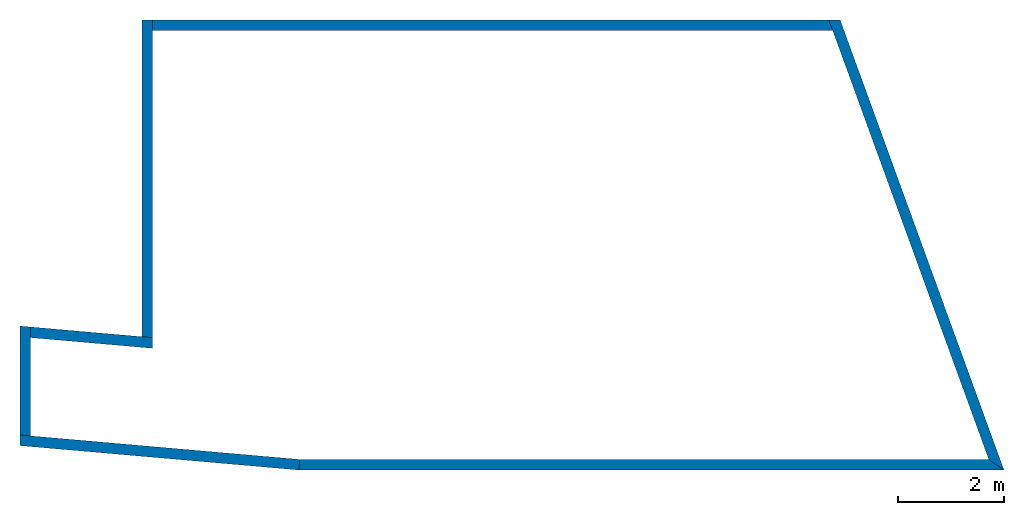
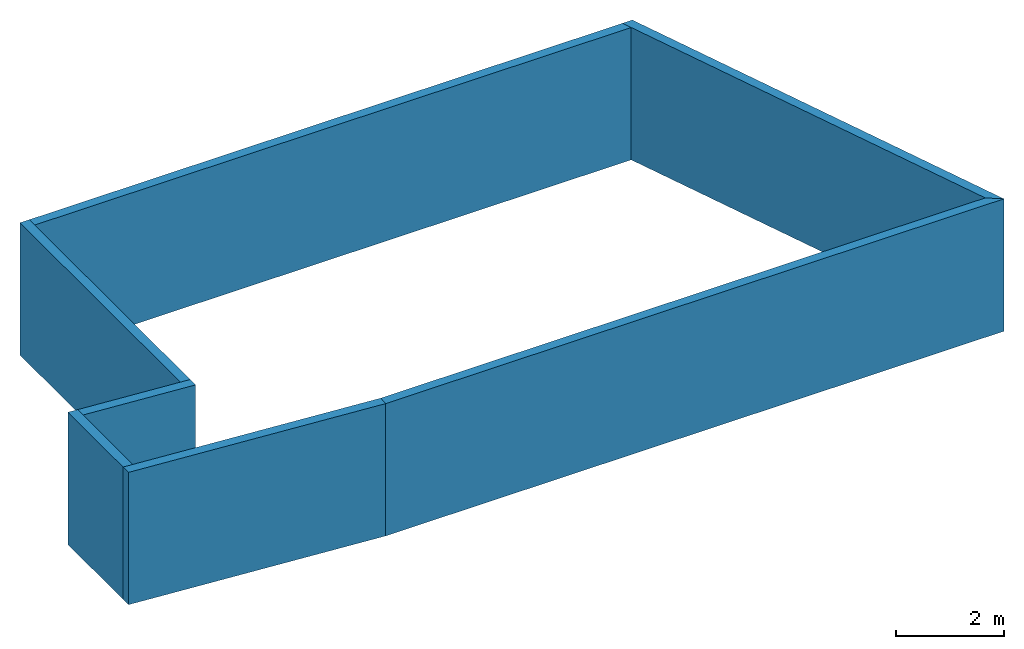
# Not in any storey: 7 walls.
"""IFC4 building model written with IfcOpenShell, lengths in metres."""

from ifc_helpers import new_model, si_unit, frame, origin_with_axes, place, context, subcontext, project, spatial, polygons, material, layer, layer_set, layer_usage, type_object, element, save


model = new_model("IFC4")

# Units and contexts
model_context = context("Model", 3, precision=1e-05, world=origin_with_axes())
plan_context = context("Plan", 2, precision=1e-05, world=origin_with_axes())
body_context = subcontext(model_context, "Body", "Model", "MODEL_VIEW")
ifc_project = project(units=[si_unit("VOLUMEUNIT", "CUBIC_METRE"), si_unit("AREAUNIT", "SQUARE_METRE"), si_unit("LENGTHUNIT", "METRE")], contexts=[model_context, plan_context])

# Site, building
site_placement = place(None, origin_with_axes())
site = spatial("IfcSite", under=ifc_project, at=site_placement)
building_placement = place(site_placement, origin_with_axes())
building = spatial("IfcBuilding", under=site, at=building_placement, Name="Building")

# Walls
ifc_material = material(Name="Generic")
ifc_layer = layer(ifc_material, 0.200000002980232)
ifc_layer_set = layer_set([ifc_layer])
ifc_layer_usage_1 = layer_usage(ifc_layer_set, "AXIS2", "POSITIVE", 0.0)
wall_type = type_object("IfcWallType", Name="Generic 200mm", PredefinedType="SOLIDWALL", material=ifc_layer_set)
wall_1_placement = place(building_placement, frame((-7.59588050842285, 0.63934725522995, 0.0), z_axis=(0.0, 0.0, 1.0), x_axis=(-4.37113882867379e-08, 1.0, 0.0)))
element("IfcWall", 1, at=wall_1_placement, inside=building, type_object=wall_type, material=ifc_layer_usage_1, Name="Wall", context=body_context, shape_type="Tessellation", body=[
    polygons([(0.017497718334198, 0.199999794363976, 0.0), (-1.49011611938477e-08, -1.30455948266217e-08, 0.0), (0.017497718334198, 0.199999794363976, 3.0), (-1.49011611938477e-08, -1.30455948266217e-08, 3.0), (5.97401905059814, 0.200000017881393, 0.0), (5.97401905059814, 2.02658895886998e-07, 0.0), (5.97401905059814, 0.200000017881393, 3.0), (5.97401905059814, 2.02658895886998e-07, 3.0)], [[[2, 4, 3, 1]], [[5, 7, 8, 6]], [[2, 1, 5, 6]], [[4, 8, 7, 3]], [[1, 3, 7, 5]], [[2, 6, 8, 4]]]),
])
ifc_layer_usage_2 = layer_usage(ifc_layer_set, "AXIS2", "POSITIVE", 0.0)
wall_2_placement = place(building_placement, frame((-7.59588098526001, 6.41336631774902, 0.0), z_axis=(0.0, 0.0, 1.0), x_axis=(1.0, 0.0, 0.0)))
element("IfcWall", 2, at=wall_2_placement, inside=building, type_object=wall_type, material=ifc_layer_usage_2, Name="Wall", context=body_context, shape_type="Tessellation", body=[
    polygons([(0.0, 0.199999809265137, 0.0), (0.0, 0.0, 0.0), (0.0, 0.199999809265137, 3.0), (0.0, 0.0, 3.0), (12.7168426513672, 0.199999809265137, 0.0), (12.7896366119385, 0.0, 0.0), (12.7168426513672, 0.199999809265137, 3.0), (12.7896366119385, 0.0, 3.0)], [[[2, 4, 3, 1]], [[5, 7, 8, 6]], [[2, 1, 5, 6]], [[4, 8, 7, 3]], [[1, 3, 7, 5]], [[2, 6, 8, 4]]]),
])
ifc_layer_usage_3 = layer_usage(ifc_layer_set, "AXIS2", "POSITIVE", 0.0)
wall_3_placement = place(building_placement, frame((5.12096166610718, 6.61336612701416, 0.0), z_axis=(0.0, 0.0, 1.0), x_axis=(0.342020153999329, -0.939692616462708, 0.0)))
element("IfcWall", 3, at=wall_3_placement, inside=building, type_object=wall_type, material=ifc_layer_usage_3, Name="Wall", context=body_context, shape_type="Tessellation", body=[
    polygons([(0.0727941989898682, 0.200000792741776, 0.0), (0.0, 5.0663948059082e-07, 0.0), (0.0727941989898682, 0.200000792741776, 3.0), (0.0, 5.0663948059082e-07, 3.0), (9.08055019378662, 0.20000022649765, 0.0), (8.79492092132568, -2.38418579101562e-07, 0.0), (9.08055019378662, 0.20000022649765, 3.0), (8.79492092132568, -2.38418579101562e-07, 3.0)], [[[2, 4, 3, 1]], [[5, 7, 8, 6]], [[2, 1, 5, 6]], [[4, 8, 7, 3]], [[1, 3, 7, 5]], [[2, 6, 8, 4]]]),
])
ifc_layer_usage_4 = layer_usage(ifc_layer_set, "AXIS2", "POSITIVE", 0.0)
wall_4_placement = place(building_placement, frame((8.41463184356689, -1.65115547180176, 0.0), z_axis=(0.0, 0.0, 1.0), x_axis=(-1.0, -1.50995802528087e-07, 0.0)))
element("IfcWall", 4, at=wall_4_placement, inside=building, type_object=wall_type, material=ifc_layer_usage_4, Name="Wall", context=body_context, shape_type="Tessellation", body=[
    polygons([(1.63912773132324e-07, 0.200000166893005, 0.0), (0.285631328821182, 9.40985813713269e-08, 0.0), (1.63912773132324e-07, 0.200000166893005, 3.0), (0.285631328821182, 9.40985813713269e-08, 3.0), (13.2563581466675, 0.19999997317791, 0.0), (13.2476320266724, 3.38080639039617e-08, 0.0), (13.2563581466675, 0.19999997317791, 3.0), (13.2476320266724, 3.38080639039617e-08, 3.0)], [[[2, 4, 3, 1]], [[5, 7, 8, 6]], [[2, 1, 5, 6]], [[4, 8, 7, 3]], [[1, 3, 7, 5]], [[2, 6, 8, 4]]]),
])
ifc_layer_usage_5 = layer_usage(ifc_layer_set, "AXIS2", "POSITIVE", 0.0)
wall_5_placement = place(building_placement, frame((-4.82430553436279, -1.65191793441772, 0.0), z_axis=(0.0, 0.0, 1.0), x_axis=(-0.99619472026825, 0.0871554017066956, 0.0)))
element("IfcWall", 5, at=wall_5_placement, inside=building, type_object=wall_type, material=ifc_layer_usage_5, Name="Wall", context=body_context, shape_type="Tessellation", body=[
    polygons([(2.38418579101562e-07, 0.19999872148037, 0.0), (0.00873541831970215, -9.68575477600098e-07, 0.0), (2.38418579101562e-07, 0.19999872148037, 3.0), (0.00873541831970215, -9.68575477600098e-07, 3.0), (5.26993656158447, 0.19999997317791, 0.0), (5.28743410110474, -7.45058059692383e-08, 0.0), (5.26993656158447, 0.19999997317791, 3.0), (5.28743410110474, -7.45058059692383e-08, 3.0)], [[[2, 4, 3, 1]], [[5, 7, 8, 6]], [[2, 1, 5, 6]], [[4, 8, 7, 3]], [[1, 3, 7, 5]], [[2, 6, 8, 4]]]),
])
ifc_layer_usage_6 = layer_usage(ifc_layer_set, "AXIS2", "POSITIVE", 0.0)
wall_6_placement = place(building_placement, frame((-9.89161968231201, -1.20858705043793, 0.0), z_axis=(0.0, 0.0, 1.0), x_axis=(-4.37113882867379e-08, 1.0, 0.0)))
element("IfcWall", 6, at=wall_6_placement, inside=building, type_object=wall_type, material=ifc_layer_usage_6, Name="Wall", context=body_context, shape_type="Tessellation", body=[
    polygons([(0.0174976233392954, 0.19999985396862, 0.0), (-4.44607337612979e-08, 5.28290193813064e-08, 0.0), (0.0174976233392954, 0.19999985396862, 3.0), (-4.44607337612979e-08, 5.28290193813064e-08, 3.0), (2.0662829875946, 0.199999764561653, 0.0), (2.04878520965576, -3.6726234498019e-08, 0.0), (2.0662829875946, 0.199999764561653, 3.0), (2.04878520965576, -3.6726234498019e-08, 3.0)], [[[2, 4, 3, 1]], [[5, 7, 8, 6]], [[2, 1, 5, 6]], [[4, 8, 7, 3]], [[1, 3, 7, 5]], [[2, 6, 8, 4]]]),
])
ifc_layer_usage_7 = layer_usage(ifc_layer_set, "AXIS2", "POSITIVE", 0.0)
wall_7_placement = place(building_placement, frame((-9.90905094146729, 0.640959322452545, 0.0), z_axis=(0.0, 0.0, 1.0), x_axis=(0.99619472026825, -0.0871557369828224, 0.0)))
element("IfcWall", 7, at=wall_7_placement, inside=building, type_object=wall_type, material=ifc_layer_usage_7, Name="Wall", context=body_context, shape_type="Tessellation", body=[
    polygons([(7.30156898498535e-07, 0.200000107288361, 0.0), (0.0174984633922577, 5.96046447753906e-08, 0.0), (7.30156898498535e-07, 0.200000107288361, 3.0), (0.0174984633922577, 5.96046447753906e-08, 3.0), (2.30450963973999, 0.200000107288361, 0.0), (2.32200741767883, 1.19209289550781e-07, 0.0), (2.30450963973999, 0.200000107288361, 3.0), (2.32200741767883, 1.19209289550781e-07, 3.0)], [[[2, 4, 3, 1]], [[5, 7, 8, 6]], [[2, 1, 5, 6]], [[4, 8, 7, 3]], [[1, 3, 7, 5]], [[2, 6, 8, 4]]]),
])

save(model, "model.ifc")
